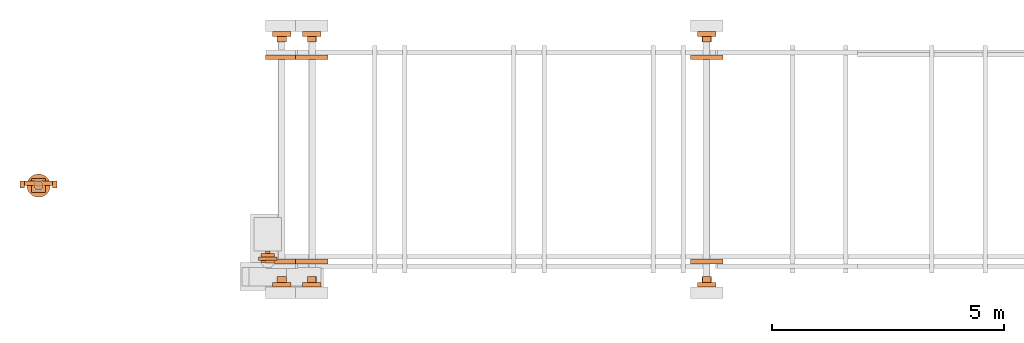
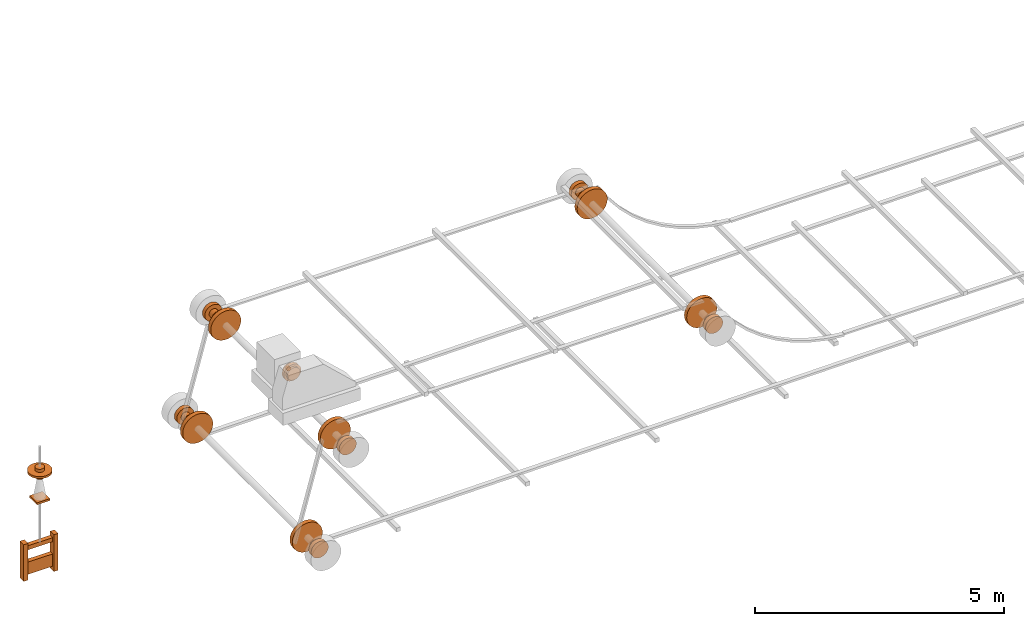
# One storey, part 4 of 6: 47 proxies.
"""IFC2X3 building model written with IfcOpenShell, lengths in millimetres."""

from ifc_helpers import new_model, entity, si_unit, converted_unit, direction, frame, origin_with_axes, origin_2d_with_axis, place, context, project, spatial, rectangle, circle, extrude, source, transform, mapped, element, save


model = new_model("IFC2X3")

# Units and contexts
model_context = context("Model", 3, precision=1e-05, world=origin_with_axes(), true_north=direction((0.0, 1.0)))
ifc_project = project(units=[si_unit("LENGTHUNIT", "METRE", prefix="MILLI"), si_unit("AREAUNIT", "SQUARE_METRE"), si_unit("VOLUMEUNIT", "CUBIC_METRE"), converted_unit("PLANEANGLEUNIT", "DEGREE", entity("IfcPlaneAngleMeasure", 0.017453293), si_unit("PLANEANGLEUNIT", "RADIAN"), dimensions=[0, 0, 0, 0, 0, 0, 0]), si_unit("SOLIDANGLEUNIT", "STERADIAN"), si_unit("MASSUNIT", "GRAM"), si_unit("TIMEUNIT", "SECOND"), si_unit("THERMODYNAMICTEMPERATUREUNIT", "DEGREE_CELSIUS"), si_unit("LUMINOUSINTENSITYUNIT", "LUMEN")], contexts=[model_context])

# Site, building, storey
site_placement = place(None, origin_with_axes())
site = spatial("IfcSite", under=ifc_project, at=site_placement, CompositionType="ELEMENT")
building_placement = place(site_placement, origin_with_axes())
building = spatial("IfcBuilding", under=site, at=building_placement, Name="Default Building", CompositionType="ELEMENT")
storey_placement = place(building_placement, frame((0.0, 0.0, 16000.0), z_axis=(0.0, 0.0, 1.0), x_axis=(1.0, 0.0, 0.0)))
storey = spatial("IfcBuildingStorey", under=building, at=storey_placement, Name="3FL", CompositionType="ELEMENT", Elevation=16000.0)

# Proxies
shared_shape_1 = source(origin_with_axes(), model_context, "Body", "SweptSolid", [
    extrude(rectangle(XDim=100.0, YDim=150.0, at=origin_2d_with_axis()), origin_with_axes(), (0.0, 0.0, 1.0), 900.0),
])
proxy_1_placement = place(storey_placement, frame((10790.275524, 23320.346832, 733.035808), z_axis=(0.0, 0.0, 1.0), x_axis=(1.0, 0.0, 0.0)))
element("IfcBuildingElementProxy", 1, at=proxy_1_placement, inside=storey, context=model_context, shape_type="MappedRepresentation", body=[
    mapped(shared_shape_1, transform((0.0, 0.0, 0.0))),
])
shared_shape_2 = source(origin_with_axes(), model_context, "Body", "SweptSolid", [
    extrude(rectangle(XDim=600.0, YDim=100.0, at=origin_2d_with_axis()), origin_with_axes(), (0.0, 0.0, 1.0), 300.0),
])
proxy_2_placement = place(storey_placement, frame((11140.449524, 23345.346832, 833.035808), z_axis=(0.0, 0.0, 1.0), x_axis=(1.0, 0.0, 0.0)))
element("IfcBuildingElementProxy", 2, at=proxy_2_placement, inside=storey, context=model_context, shape_type="MappedRepresentation", body=[
    mapped(shared_shape_2, transform((0.0, 0.0, 0.0))),
])
shared_shape_3 = source(origin_with_axes(), model_context, "Body", "SweptSolid", [
    extrude(rectangle(XDim=100.0, YDim=150.0, at=origin_2d_with_axis()), origin_with_axes(), (0.0, 0.0, 1.0), 900.0),
])
proxy_3_placement = place(storey_placement, frame((11490.449524, 23320.346832, 732.050808), z_axis=(0.0, 0.0, 1.0), x_axis=(1.0, 0.0, 0.0)))
element("IfcBuildingElementProxy", 3, at=proxy_3_placement, inside=storey, context=model_context, shape_type="MappedRepresentation", body=[
    mapped(shared_shape_3, transform((0.0, 0.0, 0.0))),
])
shared_shape_4 = source(origin_with_axes(), model_context, "Body", "SweptSolid", [
    extrude(rectangle(XDim=600.174, YDim=100.0, at=origin_2d_with_axis()), origin_with_axes(), (0.0, 0.0, 1.0), 100.0),
])
proxy_4_placement = place(storey_placement, frame((11140.362524, 23345.346832, 1433.035808), z_axis=(0.0, 0.0, 1.0), x_axis=(1.0, 0.0, 0.0)))
element("IfcBuildingElementProxy", 4, at=proxy_4_placement, inside=storey, context=model_context, shape_type="MappedRepresentation", body=[
    mapped(shared_shape_4, transform((0.0, 0.0, 0.0))),
])
shared_shape_5 = source(origin_with_axes(), model_context, "Body", "SweptSolid", [
    extrude(circle(Radius=100.0, at=origin_2d_with_axis()), origin_with_axes(), (0.0, 0.0, 1.0), 250.0),
])
proxy_5_placement = place(storey_placement, frame((11140.362524, 23295.346832, 3133.035808), z_axis=(0.0, 0.0, 1.0), x_axis=(1.0, 0.0, 0.0)))
element("IfcBuildingElementProxy", 5, at=proxy_5_placement, inside=storey, context=model_context, shape_type="MappedRepresentation", body=[
    mapped(shared_shape_5, transform((0.0, 0.0, 0.0))),
])
shared_shape_6 = source(origin_with_axes(), model_context, "Body", "SweptSolid", [
    extrude(circle(Radius=250.0, at=origin_2d_with_axis()), origin_with_axes(), (0.0, 0.0, 1.0), 50.0),
])
proxy_6_placement = place(storey_placement, frame((11140.362524, 23295.346832, 3258.035808), z_axis=(0.0, 0.0, 1.0), x_axis=(1.0, 0.0, 0.0)))
element("IfcBuildingElementProxy", 6, at=proxy_6_placement, inside=storey, context=model_context, shape_type="MappedRepresentation", body=[
    mapped(shared_shape_6, transform((0.0, 0.0, 0.0))),
])
shared_shape_7 = source(origin_with_axes(), model_context, "Body", "SweptSolid", [
    extrude(rectangle(XDim=300.0, YDim=300.0, at=origin_2d_with_axis()), origin_with_axes(), (0.0, 0.0, 1.0), 50.0),
])
proxy_7_placement = place(storey_placement, frame((11140.362524, 23295.346832, 2583.035808), z_axis=(0.0, 0.0, 1.0), x_axis=(1.0, 0.0, 0.0)))
element("IfcBuildingElementProxy", 7, at=proxy_7_placement, inside=storey, context=model_context, shape_type="MappedRepresentation", body=[
    mapped(shared_shape_7, transform((0.0, 0.0, 0.0))),
])
shared_shape_8 = source(origin_with_axes(), model_context, "Body", "SweptSolid", [
    extrude(circle(Radius=100.0, at=origin_2d_with_axis()), frame((0.0, 0.0, 0.0), z_axis=(-4.43734259186819e-31, -2.95822839457879e-31, 1.0), x_axis=(1.0, 5.91669923873109e-47, 4.43734259186819e-31)), (0.0, 0.0, 1.0), 125.0),
])
proxy_8_placement = place(storey_placement, frame((25526.115417, 21211.795807, 3139.050808), z_axis=(2.22044604925031e-16, 1.0, 1.60814287233912e-16), x_axis=(4.93038065763132e-32, 1.60814287233912e-16, -1.0)))
element("IfcBuildingElementProxy", 8, at=proxy_8_placement, inside=storey, context=model_context, shape_type="MappedRepresentation", body=[
    mapped(shared_shape_8, transform((0.0, 0.0, 0.0))),
])
shared_shape_9 = source(origin_with_axes(), model_context, "Body", "SweptSolid", [
    extrude(circle(Radius=200.0, at=origin_2d_with_axis()), frame((0.0, 0.0, 0.0), z_axis=(-4.43734259186819e-31, -2.95822839457879e-31, 1.0), x_axis=(1.0, 5.91669923873109e-47, 4.43734259186819e-31)), (0.0, 0.0, 1.0), 100.0),
])
proxy_9_placement = place(storey_placement, frame((25526.115417, 21111.795807, 3139.050808), z_axis=(2.22044604925031e-16, 1.0, 1.60814287233912e-16), x_axis=(4.93038065763132e-32, 1.60814287233912e-16, -1.0)))
element("IfcBuildingElementProxy", 9, at=proxy_9_placement, inside=storey, context=model_context, shape_type="MappedRepresentation", body=[
    mapped(shared_shape_9, transform((0.0, 0.0, 0.0))),
])
shared_shape_10 = source(origin_with_axes(), model_context, "Body", "SweptSolid", [
    extrude(circle(Radius=200.0, at=origin_2d_with_axis()), frame((0.0, 0.0, 0.0), z_axis=(-4.43734259186819e-31, -2.95822839457879e-31, 1.0), x_axis=(1.0, 5.91669923873109e-47, 4.43734259186819e-31)), (0.0, 0.0, 1.0), 100.0),
])
proxy_10_placement = place(storey_placement, frame((25526.115417, 26511.795807, 3139.050808), z_axis=(2.22044604925031e-16, 1.0, 1.60814287233912e-16), x_axis=(4.93038065763132e-32, 1.60814287233912e-16, -1.0)))
element("IfcBuildingElementProxy", 10, at=proxy_10_placement, inside=storey, context=model_context, shape_type="MappedRepresentation", body=[
    mapped(shared_shape_10, transform((0.0, 0.0, 0.0))),
])
shared_shape_11 = source(origin_with_axes(), model_context, "Body", "SweptSolid", [
    extrude(circle(Radius=350.0, at=origin_2d_with_axis()), frame((0.0, 0.0, 0.0), z_axis=(-4.43734259186819e-31, -2.95822839457879e-31, 1.0), x_axis=(1.0, 5.91669923873109e-47, 4.43734259186819e-31)), (0.0, 0.0, 1.0), 100.0),
])
proxy_11_placement = place(storey_placement, frame((25526.115417, 26011.795807, 3139.050808), z_axis=(2.22044604925031e-16, 1.0, 1.60814287233912e-16), x_axis=(4.93038065763132e-32, 1.60814287233912e-16, -1.0)))
element("IfcBuildingElementProxy", 11, at=proxy_11_placement, inside=storey, context=model_context, shape_type="MappedRepresentation", body=[
    mapped(shared_shape_11, transform((0.0, 0.0, 0.0))),
])
shared_shape_12 = source(origin_with_axes(), model_context, "Body", "SweptSolid", [
    extrude(circle(Radius=350.0, at=origin_2d_with_axis()), frame((0.0, 0.0, 0.0), z_axis=(-4.43734259186819e-31, -2.95822839457879e-31, 1.0), x_axis=(1.0, 5.91669923873109e-47, 4.43734259186819e-31)), (0.0, 0.0, 1.0), 100.0),
])
proxy_12_placement = place(storey_placement, frame((25526.115417, 21611.795807, 3139.050808), z_axis=(2.22044604925031e-16, 1.0, 1.60814287233912e-16), x_axis=(4.93038065763132e-32, 1.60814287233912e-16, -1.0)))
element("IfcBuildingElementProxy", 12, at=proxy_12_placement, inside=storey, context=model_context, shape_type="MappedRepresentation", body=[
    mapped(shared_shape_12, transform((0.0, 0.0, 0.0))),
])
shared_shape_13 = source(origin_with_axes(), model_context, "Body", "SweptSolid", [
    extrude(circle(Radius=350.0, at=origin_2d_with_axis()), frame((0.0, 0.0, 0.0), z_axis=(-4.43734259186819e-31, -2.95822839457879e-31, 1.0), x_axis=(1.0, 5.91669923873109e-47, 4.43734259186819e-31)), (0.0, 0.0, 1.0), 100.0),
])
proxy_13_placement = place(storey_placement, frame((17026.115417, 26011.795807, 3139.050808), z_axis=(2.22044604925031e-16, 1.0, 1.60814287233912e-16), x_axis=(4.93038065763132e-32, 1.60814287233912e-16, -1.0)))
element("IfcBuildingElementProxy", 13, at=proxy_13_placement, inside=storey, context=model_context, shape_type="MappedRepresentation", body=[
    mapped(shared_shape_13, transform((0.0, 0.0, 0.0))),
])
shared_shape_14 = source(origin_with_axes(), model_context, "Body", "SweptSolid", [
    extrude(circle(Radius=350.0, at=origin_2d_with_axis()), frame((0.0, 0.0, 0.0), z_axis=(-4.43734259186819e-31, -2.95822839457879e-31, 1.0), x_axis=(1.0, 5.91669923873109e-47, 4.43734259186819e-31)), (0.0, 0.0, 1.0), 100.0),
])
proxy_14_placement = place(storey_placement, frame((17026.115417, 21611.795807, 3139.050808), z_axis=(2.22044604925031e-16, 1.0, 1.60814287233912e-16), x_axis=(4.93038065763132e-32, 1.60814287233912e-16, -1.0)))
element("IfcBuildingElementProxy", 14, at=proxy_14_placement, inside=storey, context=model_context, shape_type="MappedRepresentation", body=[
    mapped(shared_shape_14, transform((0.0, 0.0, 0.0))),
])
shared_shape_15 = source(origin_with_axes(), model_context, "Body", "SweptSolid", [
    extrude(circle(Radius=100.0, at=origin_2d_with_axis()), frame((0.0, 0.0, 0.0), z_axis=(-4.43734259186819e-31, -2.95822839457879e-31, 1.0), x_axis=(1.0, 5.91669923873109e-47, 4.43734259186819e-31)), (0.0, 0.0, 1.0), 125.0),
])
proxy_15_placement = place(storey_placement, frame((17026.115417, 26386.795807, 3139.050808), z_axis=(2.22044604925031e-16, 1.0, 1.60814287233912e-16), x_axis=(4.93038065763132e-32, 1.60814287233912e-16, -1.0)))
element("IfcBuildingElementProxy", 15, at=proxy_15_placement, inside=storey, context=model_context, shape_type="MappedRepresentation", body=[
    mapped(shared_shape_15, transform((0.0, 0.0, 0.0))),
])
shared_shape_16 = source(origin_with_axes(), model_context, "Body", "SweptSolid", [
    extrude(circle(Radius=200.0, at=origin_2d_with_axis()), frame((0.0, 0.0, 0.0), z_axis=(-4.43734259186819e-31, -2.95822839457879e-31, 1.0), x_axis=(1.0, 5.91669923873109e-47, 4.43734259186819e-31)), (0.0, 0.0, 1.0), 100.0),
])
proxy_16_placement = place(storey_placement, frame((17026.115417, 26511.795807, 3139.050808), z_axis=(2.22044604925031e-16, 1.0, 1.60814287233912e-16), x_axis=(4.93038065763132e-32, 1.60814287233912e-16, -1.0)))
element("IfcBuildingElementProxy", 16, at=proxy_16_placement, inside=storey, context=model_context, shape_type="MappedRepresentation", body=[
    mapped(shared_shape_16, transform((0.0, 0.0, 0.0))),
])
shared_shape_17 = source(origin_with_axes(), model_context, "Body", "SweptSolid", [
    extrude(circle(Radius=100.0, at=origin_2d_with_axis()), frame((0.0, 0.0, 0.0), z_axis=(-4.43734259186819e-31, -2.95822839457879e-31, 1.0), x_axis=(1.0, 5.91669923873109e-47, 4.43734259186819e-31)), (0.0, 0.0, 1.0), 125.0),
])
proxy_17_placement = place(storey_placement, frame((17026.115417, 21211.795807, 3139.050808), z_axis=(2.22044604925031e-16, 1.0, 1.60814287233912e-16), x_axis=(4.93038065763132e-32, 1.60814287233912e-16, -1.0)))
element("IfcBuildingElementProxy", 17, at=proxy_17_placement, inside=storey, context=model_context, shape_type="MappedRepresentation", body=[
    mapped(shared_shape_17, transform((0.0, 0.0, 0.0))),
])
shared_shape_18 = source(origin_with_axes(), model_context, "Body", "SweptSolid", [
    extrude(circle(Radius=200.0, at=origin_2d_with_axis()), frame((0.0, 0.0, 0.0), z_axis=(-4.43734259186819e-31, -2.95822839457879e-31, 1.0), x_axis=(1.0, 5.91669923873109e-47, 4.43734259186819e-31)), (0.0, 0.0, 1.0), 100.0),
])
proxy_18_placement = place(storey_placement, frame((17026.115417, 21111.795807, 3139.050808), z_axis=(2.22044604925031e-16, 1.0, 1.60814287233912e-16), x_axis=(4.93038065763132e-32, 1.60814287233912e-16, -1.0)))
element("IfcBuildingElementProxy", 18, at=proxy_18_placement, inside=storey, context=model_context, shape_type="MappedRepresentation", body=[
    mapped(shared_shape_18, transform((0.0, 0.0, 0.0))),
])
shared_shape_19 = source(origin_with_axes(), model_context, "Body", "SweptSolid", [
    extrude(circle(Radius=350.0, at=origin_2d_with_axis()), frame((0.0, 0.0, 0.0), z_axis=(-4.43734259186819e-31, -2.95822839457879e-31, 1.0), x_axis=(1.0, 5.91669923873109e-47, 4.43734259186819e-31)), (0.0, 0.0, 1.0), 100.0),
])
proxy_19_placement = place(storey_placement, frame((16376.115417, 26011.795807, 836.521767), z_axis=(2.22044604925031e-16, 1.0, 1.60814287233912e-16), x_axis=(4.93038065763132e-32, 1.60814287233912e-16, -1.0)))
element("IfcBuildingElementProxy", 19, at=proxy_19_placement, inside=storey, context=model_context, shape_type="MappedRepresentation", body=[
    mapped(shared_shape_19, transform((0.0, 0.0, 0.0))),
])
shared_shape_20 = source(origin_with_axes(), model_context, "Body", "SweptSolid", [
    extrude(circle(Radius=350.0, at=origin_2d_with_axis()), frame((0.0, 0.0, 0.0), z_axis=(-4.43734259186819e-31, -2.95822839457879e-31, 1.0), x_axis=(1.0, 5.91669923873109e-47, 4.43734259186819e-31)), (0.0, 0.0, 1.0), 100.0),
])
proxy_20_placement = place(storey_placement, frame((16376.115417, 21611.795807, 836.521767), z_axis=(2.22044604925031e-16, 1.0, 1.60814287233912e-16), x_axis=(4.93038065763132e-32, 1.60814287233912e-16, -1.0)))
element("IfcBuildingElementProxy", 20, at=proxy_20_placement, inside=storey, context=model_context, shape_type="MappedRepresentation", body=[
    mapped(shared_shape_20, transform((0.0, 0.0, 0.0))),
])
shared_shape_21 = source(origin_with_axes(), model_context, "Body", "SweptSolid", [
    extrude(circle(Radius=100.0, at=origin_2d_with_axis()), frame((0.0, 0.0, 0.0), z_axis=(-4.43734259186819e-31, -2.95822839457879e-31, 1.0), x_axis=(1.0, 5.91669923873109e-47, 4.43734259186819e-31)), (0.0, 0.0, 1.0), 125.0),
])
proxy_21_placement = place(storey_placement, frame((16376.115417, 26386.795807, 836.521767), z_axis=(2.22044604925031e-16, 1.0, 1.60814287233912e-16), x_axis=(4.93038065763132e-32, 1.60814287233912e-16, -1.0)))
element("IfcBuildingElementProxy", 21, at=proxy_21_placement, inside=storey, context=model_context, shape_type="MappedRepresentation", body=[
    mapped(shared_shape_21, transform((0.0, 0.0, 0.0))),
])
shared_shape_22 = source(origin_with_axes(), model_context, "Body", "SweptSolid", [
    extrude(circle(Radius=200.0, at=origin_2d_with_axis()), frame((0.0, 0.0, 0.0), z_axis=(-4.43734259186819e-31, -2.95822839457879e-31, 1.0), x_axis=(1.0, 5.91669923873109e-47, 4.43734259186819e-31)), (0.0, 0.0, 1.0), 100.0),
])
proxy_22_placement = place(storey_placement, frame((16376.115417, 26511.795807, 836.521767), z_axis=(2.22044604925031e-16, 1.0, 1.60814287233912e-16), x_axis=(4.93038065763132e-32, 1.60814287233912e-16, -1.0)))
element("IfcBuildingElementProxy", 22, at=proxy_22_placement, inside=storey, context=model_context, shape_type="MappedRepresentation", body=[
    mapped(shared_shape_22, transform((0.0, 0.0, 0.0))),
])
shared_shape_23 = source(origin_with_axes(), model_context, "Body", "SweptSolid", [
    extrude(circle(Radius=100.0, at=origin_2d_with_axis()), frame((0.0, 0.0, 0.0), z_axis=(-4.43734259186819e-31, -2.95822839457879e-31, 1.0), x_axis=(1.0, 5.91669923873109e-47, 4.43734259186819e-31)), (0.0, 0.0, 1.0), 125.0),
])
proxy_23_placement = place(storey_placement, frame((16376.115417, 21211.795807, 836.521767), z_axis=(2.22044604925031e-16, 1.0, 1.60814287233912e-16), x_axis=(4.93038065763132e-32, 1.60814287233912e-16, -1.0)))
element("IfcBuildingElementProxy", 23, at=proxy_23_placement, inside=storey, context=model_context, shape_type="MappedRepresentation", body=[
    mapped(shared_shape_23, transform((0.0, 0.0, 0.0))),
])
shared_shape_24 = source(origin_with_axes(), model_context, "Body", "SweptSolid", [
    extrude(circle(Radius=200.0, at=origin_2d_with_axis()), frame((0.0, 0.0, 0.0), z_axis=(-4.43734259186819e-31, -2.95822839457879e-31, 1.0), x_axis=(1.0, 5.91669923873109e-47, 4.43734259186819e-31)), (0.0, 0.0, 1.0), 100.0),
])
proxy_24_placement = place(storey_placement, frame((16376.115417, 21111.795807, 836.521767), z_axis=(2.22044604925031e-16, 1.0, 1.60814287233912e-16), x_axis=(4.93038065763132e-32, 1.60814287233912e-16, -1.0)))
element("IfcBuildingElementProxy", 24, at=proxy_24_placement, inside=storey, context=model_context, shape_type="MappedRepresentation", body=[
    mapped(shared_shape_24, transform((0.0, 0.0, 0.0))),
])
shared_shape_25 = source(origin_with_axes(), model_context, "Body", "SweptSolid", [
    extrude(circle(Radius=100.0, at=origin_2d_with_axis()), frame((0.0, 0.0, 0.0), z_axis=(-4.43734259186819e-31, -2.95822839457879e-31, 1.0), x_axis=(1.0, 5.91669923873109e-47, 4.43734259186819e-31)), (0.0, 0.0, 1.0), 125.0),
])
proxy_25_placement = place(storey_placement, frame((25526.115417, 26386.795807, 3139.050808), z_axis=(2.22044604925031e-16, 1.0, 1.60814287233912e-16), x_axis=(4.93038065763132e-32, 1.60814287233912e-16, -1.0)))
element("IfcBuildingElementProxy", 25, at=proxy_25_placement, inside=storey, context=model_context, shape_type="MappedRepresentation", body=[
    mapped(shared_shape_25, transform((0.0, 0.0, 0.0))),
])
shared_shape_26 = source(origin_with_axes(), model_context, "Body", "SweptSolid", [
    extrude(circle(Radius=100.0, at=origin_2d_with_axis()), frame((0.0, 0.0, 0.0), z_axis=(-4.43734259186819e-31, -2.95822839457879e-31, 1.0), x_axis=(1.0, 5.91669923873109e-47, 4.43734259186819e-31)), (0.0, 0.0, 1.0), 125.0),
])
proxy_26_placement = place(storey_placement, frame((25526.115417, 21211.795807, 3139.050808), z_axis=(2.22044604925031e-16, 1.0, 1.60814287233912e-16), x_axis=(4.93038065763132e-32, 1.60814287233912e-16, -1.0)))
element("IfcBuildingElementProxy", 26, at=proxy_26_placement, inside=storey, context=model_context, shape_type="MappedRepresentation", body=[
    mapped(shared_shape_26, transform((0.0, 0.0, 0.0))),
])
shared_shape_27 = source(origin_with_axes(), model_context, "Body", "SweptSolid", [
    extrude(circle(Radius=200.0, at=origin_2d_with_axis()), frame((0.0, 0.0, 0.0), z_axis=(-4.43734259186819e-31, -2.95822839457879e-31, 1.0), x_axis=(1.0, 5.91669923873109e-47, 4.43734259186819e-31)), (0.0, 0.0, 1.0), 100.0),
])
proxy_27_placement = place(storey_placement, frame((25526.115417, 21111.795807, 3139.050808), z_axis=(2.22044604925031e-16, 1.0, 1.60814287233912e-16), x_axis=(4.93038065763132e-32, 1.60814287233912e-16, -1.0)))
element("IfcBuildingElementProxy", 27, at=proxy_27_placement, inside=storey, context=model_context, shape_type="MappedRepresentation", body=[
    mapped(shared_shape_27, transform((0.0, 0.0, 0.0))),
])
shared_shape_28 = source(origin_with_axes(), model_context, "Body", "SweptSolid", [
    extrude(circle(Radius=200.0, at=origin_2d_with_axis()), frame((0.0, 0.0, 0.0), z_axis=(-4.43734259186819e-31, -2.95822839457879e-31, 1.0), x_axis=(1.0, 5.91669923873109e-47, 4.43734259186819e-31)), (0.0, 0.0, 1.0), 100.0),
])
proxy_28_placement = place(storey_placement, frame((25526.115417, 26511.795807, 3139.050808), z_axis=(2.22044604925031e-16, 1.0, 1.60814287233912e-16), x_axis=(4.93038065763132e-32, 1.60814287233912e-16, -1.0)))
element("IfcBuildingElementProxy", 28, at=proxy_28_placement, inside=storey, context=model_context, shape_type="MappedRepresentation", body=[
    mapped(shared_shape_28, transform((0.0, 0.0, 0.0))),
])
shared_shape_29 = source(origin_with_axes(), model_context, "Body", "SweptSolid", [
    extrude(circle(Radius=350.0, at=origin_2d_with_axis()), frame((0.0, 0.0, 0.0), z_axis=(-4.43734259186819e-31, -2.95822839457879e-31, 1.0), x_axis=(1.0, 5.91669923873109e-47, 4.43734259186819e-31)), (0.0, 0.0, 1.0), 100.0),
])
proxy_29_placement = place(storey_placement, frame((25526.115417, 26011.795807, 3139.050808), z_axis=(2.22044604925031e-16, 1.0, 1.60814287233912e-16), x_axis=(4.93038065763132e-32, 1.60814287233912e-16, -1.0)))
element("IfcBuildingElementProxy", 29, at=proxy_29_placement, inside=storey, context=model_context, shape_type="MappedRepresentation", body=[
    mapped(shared_shape_29, transform((0.0, 0.0, 0.0))),
])
shared_shape_30 = source(origin_with_axes(), model_context, "Body", "SweptSolid", [
    extrude(circle(Radius=350.0, at=origin_2d_with_axis()), frame((0.0, 0.0, 0.0), z_axis=(-4.43734259186819e-31, -2.95822839457879e-31, 1.0), x_axis=(1.0, 5.91669923873109e-47, 4.43734259186819e-31)), (0.0, 0.0, 1.0), 100.0),
])
proxy_30_placement = place(storey_placement, frame((25526.115417, 21611.795807, 3139.050808), z_axis=(2.22044604925031e-16, 1.0, 1.60814287233912e-16), x_axis=(4.93038065763132e-32, 1.60814287233912e-16, -1.0)))
element("IfcBuildingElementProxy", 30, at=proxy_30_placement, inside=storey, context=model_context, shape_type="MappedRepresentation", body=[
    mapped(shared_shape_30, transform((0.0, 0.0, 0.0))),
])
shared_shape_31 = source(origin_with_axes(), model_context, "Body", "SweptSolid", [
    extrude(circle(Radius=350.0, at=origin_2d_with_axis()), frame((0.0, 0.0, 0.0), z_axis=(-4.43734259186819e-31, -2.95822839457879e-31, 1.0), x_axis=(1.0, 5.91669923873109e-47, 4.43734259186819e-31)), (0.0, 0.0, 1.0), 100.0),
])
proxy_31_placement = place(storey_placement, frame((17026.115417, 26011.795807, 3139.050808), z_axis=(2.22044604925031e-16, 1.0, 1.60814287233912e-16), x_axis=(4.93038065763132e-32, 1.60814287233912e-16, -1.0)))
element("IfcBuildingElementProxy", 31, at=proxy_31_placement, inside=storey, context=model_context, shape_type="MappedRepresentation", body=[
    mapped(shared_shape_31, transform((0.0, 0.0, 0.0))),
])
shared_shape_32 = source(origin_with_axes(), model_context, "Body", "SweptSolid", [
    extrude(circle(Radius=350.0, at=origin_2d_with_axis()), frame((0.0, 0.0, 0.0), z_axis=(-4.43734259186819e-31, -2.95822839457879e-31, 1.0), x_axis=(1.0, 5.91669923873109e-47, 4.43734259186819e-31)), (0.0, 0.0, 1.0), 100.0),
])
proxy_32_placement = place(storey_placement, frame((17026.115417, 21611.795807, 3139.050808), z_axis=(2.22044604925031e-16, 1.0, 1.60814287233912e-16), x_axis=(4.93038065763132e-32, 1.60814287233912e-16, -1.0)))
element("IfcBuildingElementProxy", 32, at=proxy_32_placement, inside=storey, context=model_context, shape_type="MappedRepresentation", body=[
    mapped(shared_shape_32, transform((0.0, 0.0, 0.0))),
])
shared_shape_33 = source(origin_with_axes(), model_context, "Body", "SweptSolid", [
    extrude(circle(Radius=100.0, at=origin_2d_with_axis()), frame((0.0, 0.0, 0.0), z_axis=(-4.43734259186819e-31, -2.95822839457879e-31, 1.0), x_axis=(1.0, 5.91669923873109e-47, 4.43734259186819e-31)), (0.0, 0.0, 1.0), 125.0),
])
proxy_33_placement = place(storey_placement, frame((17026.115417, 26386.795807, 3139.050808), z_axis=(2.22044604925031e-16, 1.0, 1.60814287233912e-16), x_axis=(4.93038065763132e-32, 1.60814287233912e-16, -1.0)))
element("IfcBuildingElementProxy", 33, at=proxy_33_placement, inside=storey, context=model_context, shape_type="MappedRepresentation", body=[
    mapped(shared_shape_33, transform((0.0, 0.0, 0.0))),
])
shared_shape_34 = source(origin_with_axes(), model_context, "Body", "SweptSolid", [
    extrude(circle(Radius=200.0, at=origin_2d_with_axis()), frame((0.0, 0.0, 0.0), z_axis=(-4.43734259186819e-31, -2.95822839457879e-31, 1.0), x_axis=(1.0, 5.91669923873109e-47, 4.43734259186819e-31)), (0.0, 0.0, 1.0), 100.0),
])
proxy_34_placement = place(storey_placement, frame((17026.115417, 26511.795807, 3139.050808), z_axis=(2.22044604925031e-16, 1.0, 1.60814287233912e-16), x_axis=(4.93038065763132e-32, 1.60814287233912e-16, -1.0)))
element("IfcBuildingElementProxy", 34, at=proxy_34_placement, inside=storey, context=model_context, shape_type="MappedRepresentation", body=[
    mapped(shared_shape_34, transform((0.0, 0.0, 0.0))),
])
shared_shape_35 = source(origin_with_axes(), model_context, "Body", "SweptSolid", [
    extrude(circle(Radius=100.0, at=origin_2d_with_axis()), frame((0.0, 0.0, 0.0), z_axis=(-4.43734259186819e-31, -2.95822839457879e-31, 1.0), x_axis=(1.0, 5.91669923873109e-47, 4.43734259186819e-31)), (0.0, 0.0, 1.0), 125.0),
])
proxy_35_placement = place(storey_placement, frame((17026.115417, 21211.795807, 3139.050808), z_axis=(2.22044604925031e-16, 1.0, 1.60814287233912e-16), x_axis=(4.93038065763132e-32, 1.60814287233912e-16, -1.0)))
element("IfcBuildingElementProxy", 35, at=proxy_35_placement, inside=storey, context=model_context, shape_type="MappedRepresentation", body=[
    mapped(shared_shape_35, transform((0.0, 0.0, 0.0))),
])
shared_shape_36 = source(origin_with_axes(), model_context, "Body", "SweptSolid", [
    extrude(circle(Radius=200.0, at=origin_2d_with_axis()), frame((0.0, 0.0, 0.0), z_axis=(-4.43734259186819e-31, -2.95822839457879e-31, 1.0), x_axis=(1.0, 5.91669923873109e-47, 4.43734259186819e-31)), (0.0, 0.0, 1.0), 100.0),
])
proxy_36_placement = place(storey_placement, frame((17026.115417, 21111.795807, 3139.050808), z_axis=(2.22044604925031e-16, 1.0, 1.60814287233912e-16), x_axis=(4.93038065763132e-32, 1.60814287233912e-16, -1.0)))
element("IfcBuildingElementProxy", 36, at=proxy_36_placement, inside=storey, context=model_context, shape_type="MappedRepresentation", body=[
    mapped(shared_shape_36, transform((0.0, 0.0, 0.0))),
])
shared_shape_37 = source(origin_with_axes(), model_context, "Body", "SweptSolid", [
    extrude(circle(Radius=350.0, at=origin_2d_with_axis()), frame((0.0, 0.0, 0.0), z_axis=(-4.43734259186819e-31, -2.95822839457879e-31, 1.0), x_axis=(1.0, 5.91669923873109e-47, 4.43734259186819e-31)), (0.0, 0.0, 1.0), 100.0),
])
proxy_37_placement = place(storey_placement, frame((16376.115417, 26011.795807, 836.521767), z_axis=(2.22044604925031e-16, 1.0, 1.60814287233912e-16), x_axis=(4.93038065763132e-32, 1.60814287233912e-16, -1.0)))
element("IfcBuildingElementProxy", 37, at=proxy_37_placement, inside=storey, context=model_context, shape_type="MappedRepresentation", body=[
    mapped(shared_shape_37, transform((0.0, 0.0, 0.0))),
])
shared_shape_38 = source(origin_with_axes(), model_context, "Body", "SweptSolid", [
    extrude(circle(Radius=350.0, at=origin_2d_with_axis()), frame((0.0, 0.0, 0.0), z_axis=(-4.43734259186819e-31, -2.95822839457879e-31, 1.0), x_axis=(1.0, 5.91669923873109e-47, 4.43734259186819e-31)), (0.0, 0.0, 1.0), 100.0),
])
proxy_38_placement = place(storey_placement, frame((16376.115417, 21611.795807, 836.521767), z_axis=(2.22044604925031e-16, 1.0, 1.60814287233912e-16), x_axis=(4.93038065763132e-32, 1.60814287233912e-16, -1.0)))
element("IfcBuildingElementProxy", 38, at=proxy_38_placement, inside=storey, context=model_context, shape_type="MappedRepresentation", body=[
    mapped(shared_shape_38, transform((0.0, 0.0, 0.0))),
])
shared_shape_39 = source(origin_with_axes(), model_context, "Body", "SweptSolid", [
    extrude(circle(Radius=100.0, at=origin_2d_with_axis()), frame((0.0, 0.0, 0.0), z_axis=(-4.43734259186819e-31, -2.95822839457879e-31, 1.0), x_axis=(1.0, 5.91669923873109e-47, 4.43734259186819e-31)), (0.0, 0.0, 1.0), 125.0),
])
proxy_39_placement = place(storey_placement, frame((16376.115417, 26386.795807, 836.521767), z_axis=(2.22044604925031e-16, 1.0, 1.60814287233912e-16), x_axis=(4.93038065763132e-32, 1.60814287233912e-16, -1.0)))
element("IfcBuildingElementProxy", 39, at=proxy_39_placement, inside=storey, context=model_context, shape_type="MappedRepresentation", body=[
    mapped(shared_shape_39, transform((0.0, 0.0, 0.0))),
])
shared_shape_40 = source(origin_with_axes(), model_context, "Body", "SweptSolid", [
    extrude(circle(Radius=200.0, at=origin_2d_with_axis()), frame((0.0, 0.0, 0.0), z_axis=(-4.43734259186819e-31, -2.95822839457879e-31, 1.0), x_axis=(1.0, 5.91669923873109e-47, 4.43734259186819e-31)), (0.0, 0.0, 1.0), 100.0),
])
proxy_40_placement = place(storey_placement, frame((16376.115417, 26511.795807, 836.521767), z_axis=(2.22044604925031e-16, 1.0, 1.60814287233912e-16), x_axis=(4.93038065763132e-32, 1.60814287233912e-16, -1.0)))
element("IfcBuildingElementProxy", 40, at=proxy_40_placement, inside=storey, context=model_context, shape_type="MappedRepresentation", body=[
    mapped(shared_shape_40, transform((0.0, 0.0, 0.0))),
])
shared_shape_41 = source(origin_with_axes(), model_context, "Body", "SweptSolid", [
    extrude(circle(Radius=100.0, at=origin_2d_with_axis()), frame((0.0, 0.0, 0.0), z_axis=(-4.43734259186819e-31, -2.95822839457879e-31, 1.0), x_axis=(1.0, 5.91669923873109e-47, 4.43734259186819e-31)), (0.0, 0.0, 1.0), 125.0),
])
proxy_41_placement = place(storey_placement, frame((16376.115417, 21211.795807, 836.521767), z_axis=(2.22044604925031e-16, 1.0, 1.60814287233912e-16), x_axis=(4.93038065763132e-32, 1.60814287233912e-16, -1.0)))
element("IfcBuildingElementProxy", 41, at=proxy_41_placement, inside=storey, context=model_context, shape_type="MappedRepresentation", body=[
    mapped(shared_shape_41, transform((0.0, 0.0, 0.0))),
])
shared_shape_42 = source(origin_with_axes(), model_context, "Body", "SweptSolid", [
    extrude(circle(Radius=200.0, at=origin_2d_with_axis()), frame((0.0, 0.0, 0.0), z_axis=(-4.43734259186819e-31, -2.95822839457879e-31, 1.0), x_axis=(1.0, 5.91669923873109e-47, 4.43734259186819e-31)), (0.0, 0.0, 1.0), 100.0),
])
proxy_42_placement = place(storey_placement, frame((16376.115417, 21111.795807, 836.521767), z_axis=(2.22044604925031e-16, 1.0, 1.60814287233912e-16), x_axis=(4.93038065763132e-32, 1.60814287233912e-16, -1.0)))
element("IfcBuildingElementProxy", 42, at=proxy_42_placement, inside=storey, context=model_context, shape_type="MappedRepresentation", body=[
    mapped(shared_shape_42, transform((0.0, 0.0, 0.0))),
])
shared_shape_43 = source(origin_with_axes(), model_context, "Body", "SweptSolid", [
    extrude(circle(Radius=100.0, at=origin_2d_with_axis()), frame((0.0, 0.0, 0.0), z_axis=(-4.43734259186819e-31, -2.95822839457879e-31, 1.0), x_axis=(1.0, 5.91669923873109e-47, 4.43734259186819e-31)), (0.0, 0.0, 1.0), 125.0),
])
proxy_43_placement = place(storey_placement, frame((25526.115417, 26386.795807, 3139.050808), z_axis=(2.22044604925031e-16, 1.0, 1.60814287233912e-16), x_axis=(4.93038065763132e-32, 1.60814287233912e-16, -1.0)))
element("IfcBuildingElementProxy", 43, at=proxy_43_placement, inside=storey, context=model_context, shape_type="MappedRepresentation", body=[
    mapped(shared_shape_43, transform((0.0, 0.0, 0.0))),
])
shared_shape_44 = source(origin_with_axes(), model_context, "Body", "SweptSolid", [
    extrude(circle(Radius=150.0, at=origin_2d_with_axis()), frame((0.0, 0.0, 0.0), z_axis=(-2.71170936169723e-31, -2.95822839457879e-31, 1.0), x_axis=(1.0, 6.90695856382025e-47, 2.71170936169723e-31)), (0.0, 0.0, 1.0), 74.9999999999545),
])
proxy_44_placement = place(storey_placement, frame((16076.115417, 21761.795807, 4932.050808), z_axis=(1.22460635382238e-16, 1.0, 2.22044604925031e-16), x_axis=(1.0, -1.22460635382238e-16, -1.23259516440783e-32)))
element("IfcBuildingElementProxy", 44, at=proxy_44_placement, inside=storey, context=model_context, shape_type="MappedRepresentation", body=[
    mapped(shared_shape_44, transform((0.0, 0.0, 0.0))),
])
shared_shape_45 = source(origin_with_axes(), model_context, "Body", "SweptSolid", [
    extrude(circle(Radius=150.0, at=origin_2d_with_axis()), frame((0.0, 0.0, 0.0), z_axis=(-2.71170936169723e-31, -2.95822839457879e-31, 1.0), x_axis=(1.0, 6.90695856382025e-47, 2.71170936169723e-31)), (0.0, 0.0, 1.0), 49.9999999998963),
])
proxy_45_placement = place(storey_placement, frame((16076.115417, 21636.795807, 4932.050808), z_axis=(1.22460635382238e-16, 1.0, 2.22044604925031e-16), x_axis=(1.0, -1.22460635382238e-16, -1.23259516440783e-32)))
element("IfcBuildingElementProxy", 45, at=proxy_45_placement, inside=storey, context=model_context, shape_type="MappedRepresentation", body=[
    mapped(shared_shape_45, transform((0.0, 0.0, 0.0))),
])
shared_shape_46 = source(origin_with_axes(), model_context, "Body", "SweptSolid", [
    extrude(circle(Radius=200.0, at=origin_2d_with_axis()), frame((0.0, 0.0, 0.0), z_axis=(-2.71170936169723e-31, -2.95822839457879e-31, 1.0), x_axis=(1.0, 6.90695856382025e-47, 2.71170936169723e-31)), (0.0, 0.0, 1.0), 75.0000000001037),
])
proxy_46_placement = place(storey_placement, frame((16076.115417, 21686.795807, 4932.050808), z_axis=(1.22460635382238e-16, 1.0, 2.22044604925031e-16), x_axis=(1.0, -1.22460635382238e-16, -1.23259516440783e-32)))
element("IfcBuildingElementProxy", 46, at=proxy_46_placement, inside=storey, context=model_context, shape_type="MappedRepresentation", body=[
    mapped(shared_shape_46, transform((0.0, 0.0, 0.0))),
])
shared_shape_47 = source(origin_with_axes(), model_context, "Body", "SweptSolid", [
    extrude(circle(Radius=50.0, at=origin_2d_with_axis()), frame((0.0, 0.0, 0.0), z_axis=(-2.71170936169723e-31, -2.95822839457879e-31, 1.0), x_axis=(1.0, 6.90695856382025e-47, 2.71170936169723e-31)), (0.0, 0.0, 1.0), 49.9999999998963),
])
proxy_47_placement = place(storey_placement, frame((16076.115417, 21836.795807, 4932.050808), z_axis=(1.22460635382238e-16, 1.0, 2.22044604925031e-16), x_axis=(1.0, -1.22460635382238e-16, -1.23259516440783e-32)))
element("IfcBuildingElementProxy", 47, at=proxy_47_placement, inside=storey, context=model_context, shape_type="MappedRepresentation", body=[
    mapped(shared_shape_47, transform((0.0, 0.0, 0.0))),
])

save(model, "model.ifc")
